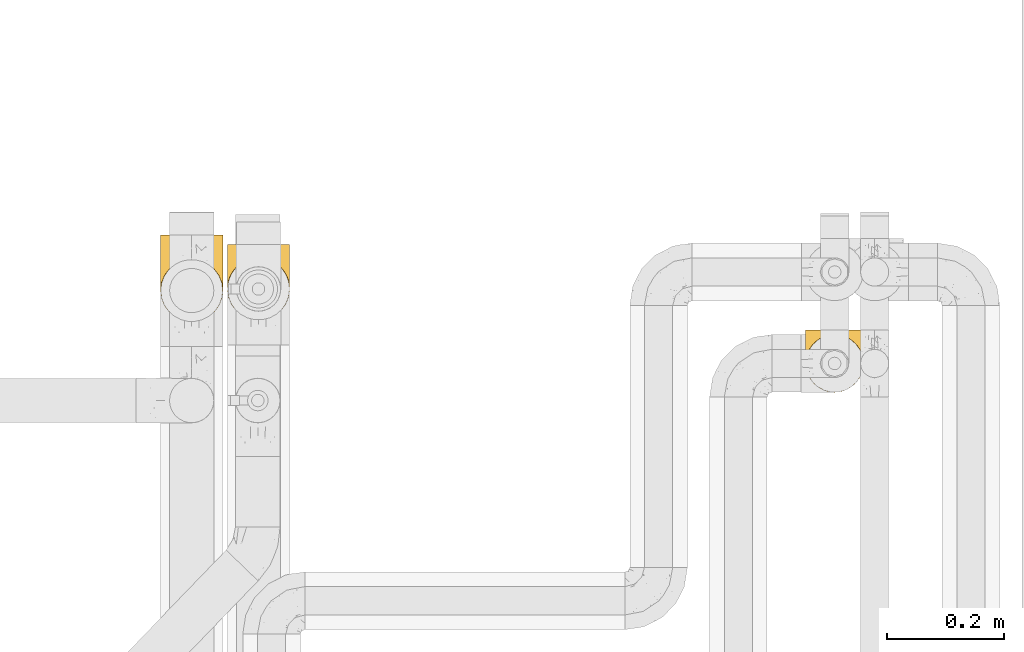
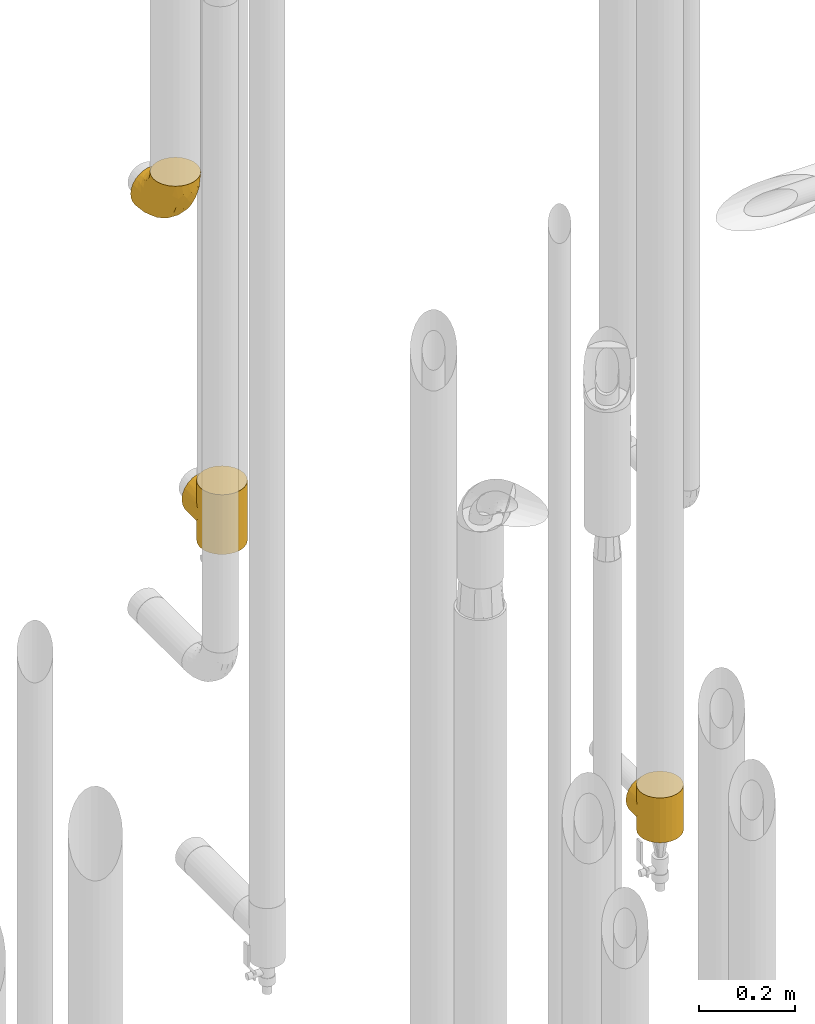
# One storey, part 400 of 827: 3 coverings.
"""IFC2X3 building model written with IfcOpenShell, lengths in millimetres."""

from ifc_helpers import new_model, entity, si_unit, converted_unit, derived_unit, direction, frame, origin, place, context, subcontext, project, spatial, faceted_brep, element, save


model = new_model("IFC2X3")

# Units and contexts
model_context = context("Model", 3, precision=0.01, world=origin(), true_north=direction((6.12303176911189e-17, 1.0)))
body_context = subcontext(model_context, "Body", "Model", "MODEL_VIEW")
ifc_project = project(units=[si_unit("LENGTHUNIT", "METRE", prefix="MILLI"), si_unit("AREAUNIT", "SQUARE_METRE"), si_unit("VOLUMEUNIT", "CUBIC_METRE"), converted_unit("PLANEANGLEUNIT", "DEGREE", entity("IfcRatioMeasure", 0.0174532925199433), si_unit("PLANEANGLEUNIT", "RADIAN"), dimensions=[0, 0, 0, 0, 0, 0, 0]), si_unit("MASSUNIT", "GRAM", prefix="KILO"), derived_unit("MASSDENSITYUNIT", [(si_unit("MASSUNIT", "GRAM", prefix="KILO"), 1), (si_unit("LENGTHUNIT", "METRE"), -3)]), derived_unit("MOMENTOFINERTIAUNIT", [(si_unit("LENGTHUNIT", "METRE"), 4)]), si_unit("TIMEUNIT", "SECOND"), si_unit("FREQUENCYUNIT", "HERTZ"), si_unit("THERMODYNAMICTEMPERATUREUNIT", "DEGREE_CELSIUS"), derived_unit("THERMALTRANSMITTANCEUNIT", [(si_unit("MASSUNIT", "GRAM", prefix="KILO"), 1), (si_unit("THERMODYNAMICTEMPERATUREUNIT", "KELVIN"), -1), (si_unit("TIMEUNIT", "SECOND"), -3)]), derived_unit("VOLUMETRICFLOWRATEUNIT", [(si_unit("LENGTHUNIT", "METRE"), 3), (si_unit("TIMEUNIT", "SECOND"), -1)]), derived_unit("MASSFLOWRATEUNIT", [(si_unit("MASSUNIT", "GRAM", prefix="KILO"), 1), (si_unit("TIMEUNIT", "SECOND"), -1)]), derived_unit("ROTATIONALFREQUENCYUNIT", [(si_unit("TIMEUNIT", "SECOND"), -1)]), si_unit("ELECTRICCURRENTUNIT", "AMPERE"), si_unit("ELECTRICVOLTAGEUNIT", "VOLT"), si_unit("POWERUNIT", "WATT"), si_unit("FORCEUNIT", "NEWTON", prefix="KILO"), si_unit("ILLUMINANCEUNIT", "LUX"), si_unit("LUMINOUSFLUXUNIT", "LUMEN"), si_unit("LUMINOUSINTENSITYUNIT", "CANDELA"), derived_unit("USERDEFINED", [(si_unit("MASSUNIT", "GRAM", prefix="KILO"), -1), (si_unit("LENGTHUNIT", "METRE"), -2), (si_unit("TIMEUNIT", "SECOND"), 3), (si_unit("LUMINOUSFLUXUNIT", "LUMEN"), 1)]), derived_unit("LINEARVELOCITYUNIT", [(si_unit("LENGTHUNIT", "METRE"), 1), (si_unit("TIMEUNIT", "SECOND"), -1)]), si_unit("PRESSUREUNIT", "PASCAL"), derived_unit("USERDEFINED", [(si_unit("LENGTHUNIT", "METRE"), -2), (si_unit("MASSUNIT", "GRAM", prefix="KILO"), 1), (si_unit("TIMEUNIT", "SECOND"), -2)]), derived_unit("LINEARFORCEUNIT", [(si_unit("MASSUNIT", "GRAM", prefix="KILO"), 1), (si_unit("LENGTHUNIT", "METRE"), 1), (si_unit("TIMEUNIT", "SECOND"), -2), (si_unit("LENGTHUNIT", "METRE"), -1)]), derived_unit("PLANARFORCEUNIT", [(si_unit("MASSUNIT", "GRAM", prefix="KILO"), 1), (si_unit("LENGTHUNIT", "METRE"), 1), (si_unit("TIMEUNIT", "SECOND"), -2), (si_unit("LENGTHUNIT", "METRE"), -2)])], contexts=[model_context])

# Site, building, storey
site_placement = place(None, origin())
site = spatial("IfcSite", under=ifc_project, at=site_placement, CompositionType="ELEMENT")
building_placement = place(site_placement, origin())
building = spatial("IfcBuilding", under=site, at=building_placement, CompositionType="ELEMENT")
storey_placement = place(building_placement, frame((0.0, 0.0, 28200.0)))
storey = spatial("IfcBuildingStorey", under=building, at=storey_placement, Name="08", CompositionType="ELEMENT", Elevation=28200.0)

# Coverings
covering_1_placement = place(storey_placement, frame((47601.0, 15100.49, 363.25)))
element("IfcCovering", 1, at=covering_1_placement, inside=storey, Name=":ADSK_", ObjectType=":ADSK_", PredefinedType="INSULATION", context=body_context, shape_type="Brep", body=[
    faceted_brep([(53.93, 99.48, 114.0), (57.11, 99.06, 114.0), (55.89, 99.35, 105.6), (61.04, 98.8, 105.06), (60.29, 98.64, 114.0), (63.47, 98.22, 114.0), (70.52, 95.74, 102.0), (69.39, 95.77, 114.0), (75.32, 93.31, 114.0), (65.78, 97.27, 103.53), (78.69, 91.18, 97.43), (80.41, 89.4, 114.0), (85.44, 85.56, 91.82), (74.6, 93.46, 99.71), (53.32, 99.62, 105.88), (50.75, 99.9, 114.0), (85.5, 85.5, 114.0), (90.79, 79.24, 85.5), (93.31, 75.32, 114.0), (94.84, 72.45, 78.71), (98.22, 63.47, 114.0), (99.34, 58.1, 64.35), (99.9, 50.75, 114.0), (50.75, 99.9, 106.15), (53.32, 99.62, 8.12), (50.75, 99.9, 0.0), (50.75, 99.9, 7.85), (97.67, 65.36, 71.62), (99.9, 50.75, 57.0), (99.34, 58.1, 49.65), (99.9, 50.75, 0.0), (2.04, 57.36, 63.62), (1.6, 50.75, 114.0), (3.27, 63.47, 114.0), (8.18, 75.32, 114.0), (5.67, 70.35, 76.6), (13.2, 82.47, 88.72), (15.99, 85.5, 114.0), (8.92, 76.57, 82.82), (1.6, 50.75, 57.0), (2.04, 57.36, 50.38), (1.6, 50.75, 0.0), (46.1, 99.45, 105.71), (44.38, 99.06, 114.0), (47.57, 99.48, 114.0), (3.39, 63.92, 70.17), (47.57, 99.48, 0.0), (18.57, 87.9, 94.16), (26.17, 93.31, 114.0), (32.1, 95.77, 114.0), (38.02, 98.22, 114.0), (37.11, 97.75, 104.0), (41.45, 99.01, 105.26), (25.1, 92.68, 98.93), (32.77, 96.49, 102.75), (41.2, 98.64, 114.0), (75.32, 8.18, 0.0), (63.47, 3.27, 0.0), (50.75, 1.6, 0.0), (38.02, 3.27, 0.0), (26.17, 8.18, 0.0), (15.99, 15.99, 0.0), (8.18, 26.17, 0.0), (3.27, 38.02, 0.0), (3.27, 63.47, 0.0), (8.18, 75.32, 0.0), (15.99, 85.5, 0.0), (26.17, 93.31, 0.0), (32.1, 95.77, 0.0), (38.02, 98.22, 0.0), (41.2, 98.64, 0.0), (44.38, 99.06, 0.0), (53.93, 99.48, 0.0), (57.11, 99.06, 0.0), (60.29, 98.64, 0.0), (63.47, 98.22, 0.0), (69.39, 95.77, 0.0), (75.32, 93.31, 0.0), (80.41, 89.4, 0.0), (85.5, 85.5, 0.0), (93.31, 75.32, 0.0), (98.22, 63.47, 0.0), (98.22, 38.02, 0.0), (93.31, 26.17, 0.0), (85.5, 15.99, 0.0), (3.27, 38.02, 114.0), (8.18, 26.17, 114.0), (15.99, 15.99, 114.0), (26.17, 8.18, 114.0), (38.02, 3.27, 114.0), (50.75, 1.6, 114.0), (63.47, 3.27, 114.0), (75.32, 8.18, 114.0), (85.5, 15.99, 114.0), (93.31, 26.17, 114.0), (98.22, 38.02, 114.0), (3.39, 63.92, 43.83), (5.67, 70.35, 37.4), (46.1, 99.45, 8.29), (8.92, 76.57, 31.18), (13.2, 82.47, 25.28), (41.45, 99.01, 8.74), (18.57, 87.9, 19.84), (25.1, 92.68, 15.07), (37.11, 97.75, 10.0), (32.77, 96.49, 11.25), (70.52, 95.74, 12.0), (65.78, 97.27, 10.47), (78.69, 91.18, 16.57), (61.04, 98.8, 8.94), (85.44, 85.56, 22.18), (74.6, 93.46, 14.29), (55.89, 99.35, 8.4), (94.84, 72.45, 35.29), (97.67, 65.36, 42.38), (90.79, 79.24, 28.5), (3.27, 107.75, 69.72), (8.18, 107.75, 81.57), (15.99, 107.75, 91.75), (26.17, 107.75, 99.57), (32.1, 107.75, 102.02), (38.02, 107.75, 104.48), (41.2, 107.75, 104.89), (44.38, 107.75, 105.31), (47.57, 107.75, 105.73), (50.75, 107.75, 106.15), (53.93, 107.75, 105.73), (57.11, 107.75, 105.31), (60.29, 107.75, 104.89), (63.47, 107.75, 104.48), (69.39, 107.75, 102.02), (75.32, 107.75, 99.57), (80.41, 107.75, 95.66), (85.5, 107.75, 91.75), (93.31, 107.75, 81.57), (98.22, 107.75, 69.72), (99.9, 107.75, 57.0), (98.22, 107.75, 44.28), (93.31, 107.75, 32.42), (85.5, 107.75, 22.25), (80.41, 107.75, 18.34), (75.32, 107.75, 14.43), (69.39, 107.75, 11.98), (63.47, 107.75, 9.52), (60.29, 107.75, 9.11), (57.11, 107.75, 8.69), (53.93, 107.75, 8.27), (50.75, 107.75, 7.85), (47.57, 107.75, 8.27), (44.38, 107.75, 8.69), (41.2, 107.75, 9.11), (38.02, 107.75, 9.52), (32.1, 107.75, 11.98), (26.17, 107.75, 14.43), (15.99, 107.75, 22.25), (8.18, 107.75, 32.42), (3.27, 107.75, 44.28), (1.6, 107.75, 57.0)], [[[0, 1, 2]], [[3, 1, 4, 5]], [[6, 7, 8]], [[9, 7, 6]], [[9, 3, 5]], [[10, 8, 11]], [[12, 10, 11]], [[6, 8, 10, 13]], [[14, 15, 0]], [[11, 16, 12]], [[17, 16, 18]], [[19, 18, 20]], [[21, 20, 22]], [[19, 17, 18]], [[15, 14, 23]], [[24, 25, 26]], [[21, 27, 20]], [[28, 21, 22]], [[29, 28, 30]], [[1, 3, 2]], [[19, 20, 27]], [[7, 9, 5]], [[16, 17, 12]], [[0, 2, 14]], [[31, 32, 33]], [[33, 34, 35]], [[36, 34, 37]], [[36, 38, 34]], [[31, 39, 32]], [[39, 40, 41]], [[42, 43, 44]], [[35, 45, 33]], [[38, 35, 34]], [[31, 33, 45]], [[23, 44, 15]], [[46, 26, 25]], [[47, 37, 48]], [[49, 50, 51]], [[23, 42, 44]], [[50, 52, 51]], [[53, 47, 48]], [[54, 48, 49]], [[54, 49, 51]], [[52, 43, 42]], [[52, 50, 55, 43]], [[53, 48, 54]], [[37, 47, 36]], [[56, 57, 58, 59, 60, 61, 62, 63, 41, 64, 65, 66, 67, 68, 69, 70, 71, 46, 25, 72, 73, 74, 75, 76, 77, 78, 79, 80, 81, 30, 82, 83, 84]], [[85, 86, 87, 88, 89, 90, 91, 92, 93, 94, 95, 22, 20, 18, 16, 11, 8, 7, 5, 4, 1, 0, 15, 44, 43, 55, 50, 49, 48, 37, 34, 33, 32]], [[88, 87, 61, 60]], [[58, 90, 89, 59]], [[89, 88, 60, 59]], [[62, 86, 85, 63]], [[32, 39, 41, 63, 85]], [[61, 87, 86, 62]], [[96, 97, 64]], [[26, 46, 98]], [[40, 96, 64]], [[41, 40, 64]], [[65, 99, 100]], [[65, 64, 97]], [[71, 101, 98]], [[65, 100, 66]], [[99, 65, 97]], [[102, 103, 67]], [[104, 68, 105]], [[104, 101, 69]], [[68, 104, 69]], [[103, 105, 67]], [[66, 102, 67]], [[101, 71, 70, 69]], [[68, 67, 105]], [[98, 46, 71]], [[102, 66, 100]], [[106, 76, 107]], [[106, 77, 76]], [[77, 108, 78]], [[109, 75, 74, 73]], [[110, 78, 108]], [[111, 108, 77, 106]], [[25, 24, 72]], [[109, 73, 112]], [[72, 24, 112]], [[76, 75, 107]], [[110, 79, 78]], [[75, 109, 107]], [[113, 114, 81]], [[114, 29, 81]], [[79, 115, 80]], [[115, 79, 110]], [[113, 80, 115]], [[113, 81, 80]], [[29, 30, 81]], [[112, 73, 72]], [[28, 22, 95, 82, 30]], [[82, 95, 94, 83]], [[94, 93, 84, 83]], [[84, 93, 92, 56]], [[56, 92, 91, 57]], [[57, 91, 90, 58]], [[116, 117, 118, 119, 120, 121, 122, 123, 124, 125, 126, 127, 128, 129, 130, 131, 132, 133, 134, 135, 136, 137, 138, 139, 140, 141, 142, 143, 144, 145, 146, 147, 148, 149, 150, 151, 152, 153, 154, 155, 156, 157]], [[52, 123, 122, 121]], [[119, 118, 47]], [[23, 124, 42]], [[54, 120, 119]], [[124, 23, 125]], [[124, 123, 42]], [[120, 51, 121]], [[53, 54, 119]], [[47, 53, 119]], [[51, 120, 54]], [[52, 121, 51]], [[118, 36, 47]], [[38, 36, 117]], [[117, 36, 118]], [[35, 117, 116]], [[31, 116, 157]], [[35, 38, 117]], [[31, 45, 116]], [[39, 31, 157]], [[35, 116, 45]], [[123, 52, 42]], [[40, 157, 156]], [[156, 155, 97]], [[100, 155, 154]], [[100, 99, 155]], [[40, 39, 157]], [[98, 149, 148]], [[97, 96, 156]], [[99, 97, 155]], [[40, 156, 96]], [[26, 148, 147]], [[102, 154, 153]], [[152, 151, 104]], [[26, 98, 148]], [[151, 101, 104]], [[103, 102, 153]], [[105, 153, 152]], [[105, 152, 104]], [[101, 149, 98]], [[101, 151, 150, 149]], [[103, 153, 105]], [[154, 102, 100]], [[146, 145, 112]], [[109, 145, 144, 143]], [[106, 142, 141]], [[107, 142, 106]], [[107, 109, 143]], [[108, 141, 140]], [[110, 108, 140]], [[106, 141, 108, 111]], [[24, 147, 146]], [[140, 139, 110]], [[115, 139, 138]], [[113, 138, 137]], [[29, 137, 136]], [[113, 115, 138]], [[147, 24, 26]], [[29, 114, 137]], [[28, 29, 136]], [[145, 109, 112]], [[113, 137, 114]], [[142, 107, 143]], [[139, 115, 110]], [[146, 112, 24]], [[21, 136, 135]], [[135, 134, 19]], [[17, 134, 133]], [[17, 19, 134]], [[14, 125, 23]], [[21, 28, 136]], [[3, 129, 128, 127]], [[19, 27, 135]], [[21, 135, 27]], [[2, 127, 126]], [[131, 6, 13, 10]], [[125, 14, 126]], [[10, 132, 131]], [[130, 129, 9]], [[14, 2, 126]], [[12, 133, 132]], [[12, 132, 10]], [[6, 130, 9]], [[3, 127, 2]], [[6, 131, 130]], [[129, 3, 9]], [[133, 12, 17]]]),
])
covering_2_placement = place(storey_placement, frame((46615.92, 15223.43, 1366.25)))
element("IfcCovering", 2, at=covering_2_placement, inside=storey, Name=":ADSK_", ObjectType=":ADSK_", PredefinedType="INSULATION", context=body_context, shape_type="Brep", body=[
    faceted_brep([(2.08, 61.79, 83.14), (1.6, 54.65, 152.0), (3.4, 68.38, 152.0), (8.7, 81.17, 152.0), (6.0, 75.81, 97.16), (14.13, 88.89, 110.24), (17.13, 92.16, 152.0), (9.51, 82.52, 103.87), (1.6, 54.65, 76.0), (2.08, 61.79, 68.86), (1.6, 54.65, 0.0), (3.54, 68.87, 90.22), (19.93, 94.76, 116.11), (28.12, 100.59, 152.0), (35.26, 104.03, 125.38), (34.52, 103.24, 152.0), (40.91, 105.89, 152.0), (47.78, 106.79, 152.0), (54.65, 107.7, 152.0), (54.65, 107.7, 129.05), (47.78, 106.79, 0.0), (54.65, 107.7, 22.95), (54.65, 107.7, 0.0), (26.97, 99.91, 121.26), (44.63, 106.74, 128.1), (65.76, 106.52, 127.87), (65.76, 106.52, 24.13), (68.38, 105.89, 152.0), (75.98, 103.22, 124.57), (74.77, 103.24, 152.0), (81.17, 100.59, 152.0), (92.16, 92.16, 152.0), (92.09, 92.23, 113.58), (84.81, 98.29, 119.64), (97.87, 85.4, 106.76), (100.59, 81.17, 152.0), (102.24, 78.08, 99.43), (105.89, 68.38, 152.0), (107.1, 62.58, 83.94), (107.7, 54.65, 152.0), (105.29, 70.43, 91.78), (107.7, 54.65, 76.0), (107.1, 62.58, 68.06), (107.7, 54.65, 0.0), (68.38, 3.4, 0.0), (54.65, 1.6, 0.0), (40.91, 3.4, 0.0), (28.12, 8.7, 0.0), (17.13, 17.13, 0.0), (8.7, 28.12, 0.0), (3.4, 40.91, 0.0), (3.4, 68.38, 0.0), (8.7, 81.17, 0.0), (17.13, 92.16, 0.0), (28.12, 100.59, 0.0), (34.52, 103.24, 0.0), (40.91, 105.89, 0.0), (68.38, 105.89, 0.0), (74.77, 103.24, 0.0), (81.17, 100.59, 0.0), (92.16, 92.16, 0.0), (100.59, 81.17, 0.0), (105.89, 68.38, 0.0), (105.89, 40.91, 0.0), (100.59, 28.12, 0.0), (92.16, 17.13, 0.0), (81.17, 8.7, 0.0), (3.4, 40.91, 152.0), (8.7, 28.12, 152.0), (17.13, 17.13, 152.0), (28.12, 8.7, 152.0), (40.91, 3.4, 152.0), (54.65, 1.6, 152.0), (68.38, 3.4, 152.0), (81.17, 8.7, 152.0), (92.16, 17.13, 152.0), (100.59, 28.12, 152.0), (105.89, 40.91, 152.0), (3.54, 68.87, 61.78), (6.0, 75.81, 54.84), (9.51, 82.52, 48.13), (14.13, 88.89, 41.76), (19.93, 94.76, 35.89), (26.97, 99.91, 30.74), (35.26, 104.03, 26.62), (44.63, 106.74, 23.9), (75.98, 103.22, 27.43), (84.81, 98.29, 32.36), (92.09, 92.23, 38.42), (102.24, 78.08, 52.57), (105.29, 70.43, 60.22), (97.87, 85.4, 45.24), (1.6, 130.65, 76.0), (3.4, 130.65, 89.73), (8.7, 130.65, 102.53), (17.13, 130.65, 113.51), (28.12, 130.65, 121.94), (34.52, 130.65, 124.59), (40.91, 130.65, 127.24), (47.78, 130.65, 128.15), (54.65, 130.65, 129.05), (68.38, 130.65, 127.24), (74.77, 130.65, 124.59), (81.17, 130.65, 121.94), (92.16, 130.65, 113.51), (100.59, 130.65, 102.53), (105.89, 130.65, 89.73), (107.7, 130.65, 76.0), (105.89, 130.65, 62.27), (100.59, 130.65, 49.47), (92.16, 130.65, 38.49), (81.17, 130.65, 30.06), (74.77, 130.65, 27.41), (68.38, 130.65, 24.76), (54.65, 130.65, 22.95), (47.78, 130.65, 23.85), (40.91, 130.65, 24.76), (34.52, 130.65, 27.41), (28.12, 130.65, 30.06), (17.13, 130.65, 38.49), (8.7, 130.65, 49.47), (3.4, 130.65, 62.27)], [[[0, 1, 2]], [[2, 3, 4]], [[5, 3, 6]], [[5, 7, 3]], [[0, 8, 1]], [[8, 9, 10]], [[4, 11, 2]], [[7, 4, 3]], [[0, 2, 11]], [[12, 6, 13]], [[14, 13, 15, 16]], [[17, 18, 19]], [[20, 21, 22]], [[23, 12, 13]], [[24, 14, 16]], [[24, 17, 19]], [[24, 16, 17]], [[23, 13, 14]], [[6, 12, 5]], [[25, 19, 18]], [[21, 26, 22]], [[25, 18, 27]], [[28, 27, 29, 30]], [[28, 25, 27]], [[31, 32, 33]], [[28, 30, 33]], [[33, 30, 31]], [[34, 31, 35]], [[36, 35, 37]], [[38, 37, 39]], [[36, 34, 35]], [[38, 40, 37]], [[41, 38, 39]], [[42, 41, 43]], [[36, 37, 40]], [[31, 34, 32]], [[44, 45, 46, 47, 48, 49, 50, 10, 51, 52, 53, 54, 55, 56, 20, 22, 57, 58, 59, 60, 61, 62, 43, 63, 64, 65, 66]], [[1, 67, 68, 69, 70, 71, 72, 73, 74, 75, 76, 77, 39, 37, 35, 31, 30, 29, 27, 18, 17, 16, 15, 13, 6, 3, 2]], [[70, 69, 48, 47]], [[45, 72, 71, 46]], [[46, 71, 70, 47]], [[49, 68, 67, 50]], [[1, 8, 10, 50, 67]], [[48, 69, 68, 49]], [[78, 79, 51]], [[9, 78, 51]], [[10, 9, 51]], [[52, 80, 81]], [[52, 51, 79]], [[52, 81, 53]], [[80, 52, 79]], [[82, 83, 54]], [[84, 56, 55, 54]], [[84, 85, 56]], [[21, 20, 85]], [[83, 84, 54]], [[53, 82, 54]], [[85, 20, 56]], [[82, 53, 81]], [[26, 86, 57]], [[59, 87, 60]], [[86, 59, 58, 57]], [[86, 87, 59]], [[22, 26, 57]], [[87, 88, 60]], [[89, 90, 62]], [[90, 42, 62]], [[60, 91, 61]], [[91, 60, 88]], [[89, 61, 91]], [[89, 62, 61]], [[42, 43, 62]], [[41, 39, 77, 63, 43]], [[63, 77, 76, 64]], [[76, 75, 65, 64]], [[65, 75, 74, 66]], [[66, 74, 73, 44]], [[44, 73, 72, 45]], [[92, 93, 94, 95, 96, 97, 98, 99, 100, 101, 102, 103, 104, 105, 106, 107, 108, 109, 110, 111, 112, 113, 114, 115, 116, 117, 118, 119, 120, 121]], [[24, 99, 98]], [[96, 95, 12]], [[14, 98, 97, 96]], [[19, 99, 24]], [[19, 100, 99]], [[23, 14, 96]], [[12, 23, 96]], [[24, 98, 14]], [[95, 5, 12]], [[7, 5, 94]], [[94, 5, 95]], [[4, 94, 93]], [[0, 93, 92]], [[4, 7, 94]], [[0, 11, 93]], [[8, 0, 92]], [[4, 93, 11]], [[9, 92, 121]], [[121, 120, 79]], [[81, 120, 119]], [[81, 80, 120]], [[9, 8, 92]], [[79, 78, 121]], [[80, 79, 120]], [[9, 121, 78]], [[82, 119, 118]], [[84, 118, 117, 116]], [[115, 114, 21]], [[83, 82, 118]], [[85, 84, 116]], [[85, 115, 21]], [[85, 116, 115]], [[83, 118, 84]], [[119, 82, 81]], [[26, 21, 114]], [[26, 114, 113]], [[86, 113, 112, 111]], [[86, 26, 113]], [[110, 88, 87]], [[86, 111, 87]], [[87, 111, 110]], [[91, 110, 109]], [[89, 109, 108]], [[42, 108, 107]], [[89, 91, 109]], [[42, 90, 108]], [[41, 42, 107]], [[89, 108, 90]], [[110, 91, 88]], [[38, 107, 106]], [[106, 105, 36]], [[34, 105, 104]], [[34, 36, 105]], [[38, 41, 107]], [[36, 40, 106]], [[38, 106, 40]], [[33, 104, 103]], [[28, 103, 102, 101]], [[25, 101, 100]], [[33, 32, 104]], [[25, 28, 101]], [[19, 25, 100]], [[33, 103, 28]], [[104, 32, 34]]]),
])
covering_3_placement = place(storey_placement, frame((46502.13, 15220.72, 2195.4)))
element("IfcCovering", 3, at=covering_3_placement, inside=storey, Name=":ADSK_", ObjectType=":ADSK_", PredefinedType="INSULATION", context=body_context, shape_type="Brep", body=[
    faceted_brep([(66.44, 149.65, 2.92), (54.65, 149.65, 1.6), (42.84, 149.65, 2.93), (31.62, 149.65, 6.85), (21.56, 149.65, 13.18), (13.16, 149.65, 21.58), (6.84, 149.65, 31.64), (2.92, 149.65, 42.85), (1.6, 149.65, 54.65), (2.93, 149.65, 66.46), (6.85, 149.65, 77.67), (13.18, 149.65, 87.73), (21.58, 149.65, 96.13), (31.64, 149.65, 102.45), (42.85, 149.65, 106.37), (54.65, 149.65, 107.7), (66.46, 149.65, 106.36), (77.67, 149.65, 102.44), (87.73, 149.65, 96.11), (96.13, 149.65, 87.71), (102.45, 149.65, 77.65), (106.37, 149.65, 66.44), (107.7, 149.65, 54.65), (106.36, 149.65, 42.84), (102.44, 149.65, 31.62), (96.11, 149.65, 21.56), (87.71, 149.65, 13.16), (77.65, 149.65, 6.84), (40.91, 105.89, 149.65), (28.12, 100.59, 149.65), (17.13, 92.16, 149.65), (8.7, 81.17, 149.65), (3.4, 68.38, 149.65), (1.6, 54.65, 149.65), (3.4, 40.91, 149.65), (8.7, 28.12, 149.65), (17.13, 17.13, 149.65), (28.12, 8.7, 149.65), (40.91, 3.4, 149.65), (54.65, 1.6, 149.65), (68.38, 3.4, 149.65), (81.17, 8.7, 149.65), (92.16, 17.13, 149.65), (100.59, 28.12, 149.65), (105.89, 40.91, 149.65), (107.7, 54.65, 149.65), (105.89, 68.38, 149.65), (100.59, 81.17, 149.65), (92.16, 92.16, 149.65), (81.17, 100.59, 149.65), (68.38, 105.89, 149.65), (54.65, 107.7, 149.65), (85.53, 14.05, 123.27), (73.42, 9.45, 114.15), (83.77, 22.36, 92.97), (64.22, 4.7, 124.11), (54.65, 6.64, 111.33), (96.72, 81.47, 42.13), (93.36, 56.83, 56.83), (84.47, 64.02, 40.31), (71.37, 34.04, 61.55), (54.65, 21.43, 75.62), (54.65, 44.96, 44.96), (103.47, 49.8, 91.12), (100.91, 35.43, 109.83), (99.1, 42.1, 88.02), (105.43, 43.59, 119.19), (106.79, 57.88, 99.11), (89.81, 91.8, 27.97), (79.59, 88.01, 21.92), (81.29, 115.65, 12.94), (74.01, 18.94, 88.29), (64.14, 12.83, 95.35), (94.75, 24.96, 113.84), (54.65, 111.33, 6.64), (70.74, 113.8, 8.58), (68.3, 60.89, 33.39), (66.05, 86.24, 17.23), (100.73, 65.84, 61.99), (106.78, 124.58, 47.9), (103.6, 121.36, 37.72), (107.7, 72.79, 93.81), (107.7, 66.04, 107.05), (107.7, 59.29, 120.29), (106.07, 73.26, 73.26), (90.59, 121.69, 18.58), (97.43, 109.82, 29.72), (84.51, 40.11, 64.31), (93.3, 36.57, 82.84), (107.7, 93.81, 72.79), (107.7, 83.3, 83.3), (107.7, 136.6, 56.71), (107.7, 120.29, 59.29), (106.79, 99.11, 57.88), (107.7, 107.05, 66.04), (103.47, 91.12, 49.8), (54.65, 75.62, 21.43), (107.7, 56.97, 134.97), (76.99, 126.65, 108.79), (84.28, 116.55, 110.84), (91.11, 120.09, 101.53), (106.26, 76.06, 111.84), (102.6, 83.69, 119.98), (106.08, 71.88, 123.54), (106.56, 66.92, 134.54), (105.36, 110.43, 80.57), (106.74, 121.31, 69.55), (101.59, 81.0, 134.56), (54.65, 113.32, 128.67), (54.65, 111.09, 136.98), (67.71, 109.14, 133.56), (91.36, 95.86, 131.66), (94.33, 99.07, 117.75), (87.1, 106.92, 118.23), (65.84, 131.39, 110.55), (54.65, 136.98, 111.09), (54.65, 128.67, 113.32), (68.92, 117.07, 120.2), (100.82, 96.39, 105.95), (79.83, 106.61, 127.69), (77.13, 103.72, 139.88), (105.9, 92.14, 92.14), (101.53, 107.13, 93.82), (106.72, 98.03, 82.28), (97.75, 88.38, 130.86), (103.08, 130.66, 78.78), (106.39, 135.45, 67.58), (98.1, 123.57, 90.58), (95.02, 137.75, 90.23), (86.9, 133.2, 99.39), (74.42, 138.8, 105.17), (54.65, 120.99, 120.99), (105.28, 84.53, 104.59), (92.87, 108.72, 108.24), (17.93, 95.86, 131.66), (6.22, 130.67, 78.8), (41.58, 109.13, 133.57), (1.6, 93.81, 72.79), (2.57, 98.02, 82.27), (3.94, 110.43, 80.59), (43.46, 131.4, 110.55), (32.32, 126.66, 108.79), (40.38, 117.08, 120.2), (16.44, 108.74, 108.25), (8.47, 96.31, 106.06), (15.01, 99.11, 117.78), (11.21, 123.58, 90.6), (7.78, 107.12, 93.87), (1.6, 72.79, 93.81), (1.6, 66.04, 107.05), (3.04, 76.07, 111.89), (1.6, 56.97, 134.97), (2.73, 66.92, 134.54), (1.6, 120.29, 59.29), (1.6, 107.05, 66.04), (2.55, 121.26, 69.56), (3.98, 84.46, 104.56), (6.69, 83.69, 119.98), (7.7, 81.0, 134.56), (3.21, 71.88, 123.54), (14.28, 137.76, 90.25), (22.42, 133.21, 99.4), (25.02, 116.58, 110.83), (18.18, 120.1, 101.52), (34.89, 138.81, 105.18), (1.6, 136.6, 56.71), (32.17, 103.72, 139.89), (22.23, 106.96, 118.22), (2.91, 135.44, 67.6), (11.54, 88.38, 130.86), (1.6, 83.3, 83.3), (29.46, 106.6, 127.71), (3.38, 92.12, 92.12), (1.6, 59.29, 120.29), (25.52, 22.36, 92.97), (23.76, 14.05, 123.27), (14.54, 24.96, 113.84), (8.38, 35.43, 109.83), (45.07, 4.71, 124.03), (35.87, 9.45, 114.15), (45.14, 11.79, 98.04), (2.5, 57.88, 99.11), (2.51, 124.57, 47.9), (5.68, 121.37, 37.74), (5.82, 91.12, 49.8), (15.93, 56.83, 56.83), (12.54, 81.48, 42.16), (24.81, 64.05, 40.3), (2.5, 99.11, 57.88), (3.22, 73.26, 73.26), (3.86, 43.59, 119.19), (35.85, 19.5, 86.61), (19.47, 91.8, 27.99), (18.68, 121.7, 18.59), (29.68, 88.04, 21.92), (27.95, 123.34, 11.28), (40.99, 60.89, 33.39), (37.92, 34.04, 61.55), (11.85, 109.85, 29.73), (10.19, 42.1, 88.01), (8.55, 65.78, 62.08), (38.53, 113.81, 8.58), (15.99, 36.57, 82.84), (24.79, 40.12, 64.3), (5.82, 49.8, 91.12), (40.56, 86.08, 18.05)], [[[0, 1, 2, 3, 4, 5, 6, 7, 8, 9, 10, 11, 12, 13, 14, 15, 16, 17, 18, 19, 20, 21, 22, 23, 24, 25, 26, 27]], [[28, 29, 30, 31, 32, 33, 34, 35, 36, 37, 38, 39, 40, 41, 42, 43, 44, 45, 46, 47, 48, 49, 50, 51]], [[52, 53, 54]], [[55, 39, 56]], [[57, 58, 59]], [[60, 61, 62]], [[63, 64, 65]], [[66, 63, 67]], [[68, 69, 70]], [[53, 71, 54]], [[41, 40, 53]], [[53, 72, 71]], [[73, 42, 52]], [[42, 41, 52]], [[74, 0, 75]], [[69, 76, 77]], [[43, 73, 64]], [[45, 44, 66]], [[57, 78, 58]], [[23, 79, 80]], [[67, 81, 82, 83]], [[67, 84, 81]], [[24, 23, 80]], [[25, 85, 26]], [[86, 85, 25]], [[42, 73, 43]], [[0, 27, 75]], [[25, 24, 86]], [[70, 26, 85]], [[0, 74, 1]], [[68, 85, 86]], [[66, 64, 63]], [[60, 59, 87]], [[54, 87, 88]], [[76, 60, 62]], [[84, 89, 90, 81]], [[79, 22, 91, 92]], [[77, 74, 75]], [[93, 92, 94, 89]], [[80, 86, 24]], [[40, 55, 53]], [[76, 59, 60]], [[93, 84, 95]], [[76, 62, 96]], [[55, 72, 53]], [[70, 27, 26]], [[75, 70, 69]], [[78, 84, 63]], [[93, 79, 92]], [[95, 86, 80]], [[77, 76, 96]], [[59, 69, 68]], [[57, 68, 86]], [[68, 57, 59]], [[59, 58, 87]], [[76, 69, 59]], [[88, 87, 58]], [[87, 54, 71]], [[86, 95, 57]], [[78, 57, 95]], [[84, 78, 95]], [[78, 63, 65]], [[58, 78, 65]], [[54, 88, 73]], [[84, 93, 89]], [[79, 95, 80]], [[79, 93, 95]], [[22, 79, 23]], [[66, 83, 97, 45]], [[84, 67, 63]], [[83, 66, 67]], [[64, 44, 43]], [[64, 66, 44]], [[65, 73, 88]], [[53, 52, 41]], [[73, 52, 54]], [[73, 65, 64]], [[65, 88, 58]], [[39, 55, 40]], [[72, 55, 56]], [[56, 61, 72]], [[60, 72, 61]], [[72, 60, 71]], [[87, 71, 60]], [[27, 70, 75]], [[68, 70, 85]], [[74, 77, 96]], [[69, 77, 75]], [[98, 99, 100]], [[46, 45, 97]], [[101, 102, 103]], [[103, 104, 83]], [[105, 94, 106]], [[107, 103, 102]], [[108, 109, 51, 110]], [[111, 112, 113]], [[114, 115, 116]], [[47, 104, 107]], [[110, 117, 108]], [[49, 48, 111]], [[102, 118, 112]], [[119, 120, 111]], [[50, 49, 120]], [[121, 122, 118]], [[105, 123, 89]], [[124, 48, 107]], [[20, 19, 125]], [[121, 81, 90]], [[117, 119, 99]], [[21, 20, 126]], [[22, 21, 91]], [[105, 125, 127]], [[110, 51, 50]], [[19, 128, 125]], [[16, 15, 115]], [[129, 98, 100]], [[126, 91, 21]], [[128, 129, 127]], [[122, 123, 105]], [[114, 117, 98]], [[17, 16, 130]], [[18, 128, 19]], [[129, 18, 17]], [[125, 106, 126]], [[115, 114, 16]], [[130, 129, 17]], [[114, 98, 130]], [[117, 116, 131, 108]], [[99, 119, 113]], [[122, 121, 123]], [[92, 126, 106]], [[105, 127, 122]], [[132, 121, 118]], [[114, 130, 16]], [[129, 130, 98]], [[50, 120, 110]], [[129, 128, 18]], [[125, 128, 127]], [[125, 126, 20]], [[91, 126, 92]], [[105, 89, 94]], [[105, 106, 125]], [[94, 92, 106]], [[100, 122, 127]], [[118, 122, 133]], [[112, 118, 133]], [[132, 118, 102]], [[132, 102, 101]], [[81, 121, 132]], [[82, 103, 83]], [[132, 101, 81]], [[104, 47, 46]], [[124, 107, 102]], [[48, 47, 107]], [[113, 112, 133]], [[112, 111, 124]], [[99, 113, 133]], [[111, 113, 119]], [[99, 133, 100]], [[117, 99, 98]], [[122, 100, 133]], [[127, 129, 100]], [[103, 82, 101]], [[81, 101, 82]], [[112, 124, 102]], [[48, 124, 111]], [[104, 103, 107]], [[46, 97, 104]], [[111, 120, 49]], [[83, 104, 97]], [[110, 120, 119]], [[117, 110, 119]], [[116, 117, 114]], [[123, 90, 89]], [[90, 123, 121]], [[30, 29, 134]], [[11, 10, 135]], [[51, 109, 108, 136]], [[137, 138, 139]], [[140, 141, 142]], [[143, 144, 145]], [[146, 139, 147]], [[148, 149, 150]], [[151, 32, 152]], [[153, 154, 155]], [[156, 150, 157]], [[158, 157, 159]], [[108, 142, 136]], [[31, 158, 152]], [[160, 161, 12]], [[162, 163, 143]], [[140, 142, 116]], [[142, 141, 162]], [[14, 164, 140]], [[14, 140, 115]], [[9, 8, 165]], [[160, 12, 11]], [[141, 164, 161]], [[13, 12, 161]], [[14, 115, 15]], [[28, 166, 29]], [[135, 139, 146]], [[141, 163, 162]], [[135, 146, 160]], [[143, 167, 162]], [[29, 166, 134]], [[116, 142, 108, 131]], [[165, 153, 168]], [[10, 9, 168]], [[168, 135, 10]], [[138, 147, 139]], [[158, 169, 157]], [[14, 13, 164]], [[116, 115, 140]], [[145, 167, 143]], [[135, 160, 11]], [[168, 153, 155]], [[138, 137, 170]], [[157, 144, 156]], [[147, 144, 143]], [[161, 164, 13]], [[140, 164, 141]], [[142, 171, 136]], [[136, 171, 166]], [[161, 160, 146]], [[165, 168, 9]], [[155, 139, 135]], [[139, 154, 137]], [[168, 155, 135]], [[139, 155, 154]], [[144, 147, 172]], [[163, 147, 143]], [[156, 144, 172]], [[157, 169, 145]], [[172, 148, 156]], [[173, 159, 149]], [[159, 157, 150]], [[152, 159, 173]], [[159, 152, 158]], [[31, 30, 158]], [[169, 30, 134]], [[157, 145, 144]], [[167, 134, 171]], [[134, 167, 145]], [[171, 142, 162]], [[162, 167, 171]], [[163, 141, 161]], [[161, 146, 163]], [[147, 163, 146]], [[148, 150, 156]], [[149, 159, 150]], [[30, 169, 158]], [[145, 169, 134]], [[151, 33, 32]], [[31, 152, 32]], [[152, 173, 151]], [[28, 51, 136]], [[134, 166, 171]], [[28, 136, 166]], [[138, 170, 172]], [[147, 138, 172]], [[148, 172, 170]], [[174, 175, 176]], [[35, 34, 177]], [[178, 179, 180]], [[181, 173, 149, 148]], [[182, 183, 184]], [[185, 186, 187]], [[188, 189, 137]], [[190, 33, 151, 173]], [[191, 179, 174]], [[34, 190, 177]], [[39, 38, 178]], [[192, 193, 194]], [[4, 3, 195]], [[175, 179, 37]], [[38, 37, 179]], [[35, 176, 36]], [[196, 62, 197]], [[181, 190, 173]], [[37, 36, 175]], [[183, 6, 198]], [[189, 148, 170, 137]], [[185, 199, 200]], [[3, 2, 201]], [[202, 185, 203]], [[8, 7, 182]], [[200, 184, 186]], [[183, 7, 6]], [[181, 189, 204]], [[200, 189, 184]], [[5, 198, 6]], [[187, 203, 185]], [[195, 3, 201]], [[205, 196, 194]], [[62, 61, 197]], [[186, 198, 192]], [[180, 179, 191]], [[2, 1, 74]], [[198, 193, 192]], [[193, 5, 4]], [[194, 193, 195]], [[2, 74, 201]], [[5, 193, 198]], [[205, 74, 96]], [[188, 137, 154, 153]], [[62, 196, 96]], [[56, 178, 180]], [[198, 184, 183]], [[184, 188, 182]], [[203, 197, 191]], [[205, 194, 201]], [[187, 192, 194]], [[192, 187, 186]], [[194, 196, 187]], [[197, 187, 196]], [[197, 203, 187]], [[202, 174, 176]], [[200, 186, 185]], [[184, 198, 186]], [[199, 185, 202]], [[189, 200, 204]], [[174, 202, 203]], [[176, 177, 199]], [[189, 181, 148]], [[190, 181, 204]], [[190, 204, 177]], [[190, 34, 33]], [[188, 153, 182]], [[189, 188, 184]], [[182, 153, 165, 8]], [[183, 182, 7]], [[199, 177, 204]], [[35, 177, 176]], [[176, 175, 36]], [[179, 175, 174]], [[200, 199, 204]], [[176, 199, 202]], [[203, 191, 174]], [[180, 197, 61]], [[197, 180, 191]], [[61, 56, 180]], [[39, 178, 56]], [[38, 179, 178]], [[194, 195, 201]], [[4, 195, 193]], [[74, 205, 201]], [[96, 196, 205]]]),
])

save(model, "model.ifc")
